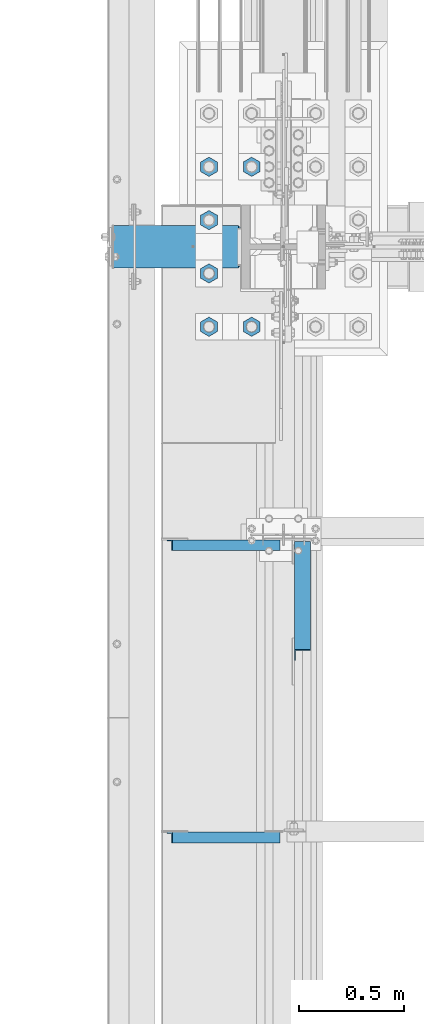
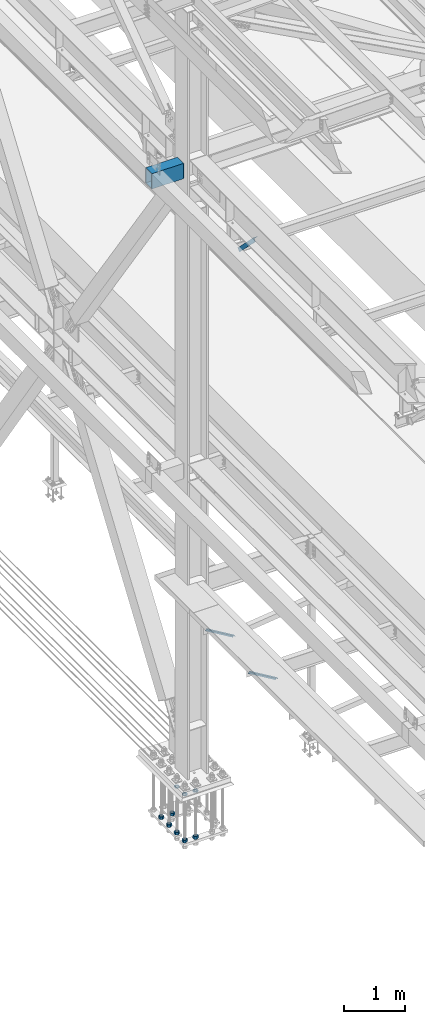
# One storey, part 2364 of 3843: 10 beams, 3 members, 5 elements without a shape of their own.
"""IFC2X3 building model written with IfcOpenShell, lengths in millimetres."""

from ifc_helpers import new_model, si_unit, frame, origin_with_axes, place, context, subcontext, project, spatial, faceted_brep, material, type_object, element, aggregate, save


model = new_model("IFC2X3")

# Units and contexts
model_context = context("Model", 3, precision=1e-05, world=origin_with_axes())
body_context = subcontext(model_context, "Body", "Model", "MODEL_VIEW")
ifc_project = project(units=[si_unit("LENGTHUNIT", "METRE", prefix="MILLI"), si_unit("AREAUNIT", "SQUARE_METRE"), si_unit("VOLUMEUNIT", "CUBIC_METRE"), si_unit("MASSUNIT", "GRAM", prefix="KILO"), si_unit("TIMEUNIT", "SECOND"), si_unit("PLANEANGLEUNIT", "RADIAN"), si_unit("SOLIDANGLEUNIT", "STERADIAN"), si_unit("THERMODYNAMICTEMPERATUREUNIT", "DEGREE_CELSIUS"), si_unit("LUMINOUSINTENSITYUNIT", "LUMEN")], contexts=[model_context])

# Site, building, storey
site_placement = place(None, origin_with_axes())
site = spatial("IfcSite", under=ifc_project, at=site_placement, CompositionType="ELEMENT")
building_placement = place(site_placement, origin_with_axes())
building = spatial("IfcBuilding", under=site, at=building_placement, Name="Undefined", CompositionType="ELEMENT")
storey_placement = place(building_placement, origin_with_axes())
storey = spatial("IfcBuildingStorey", under=building, at=storey_placement, Name="Undefined", CompositionType="ELEMENT", Elevation=0.0)

# Assembly, beams
assembly_1_placement = place(storey_placement, origin_with_axes())
assembly_1 = element("IfcElementAssembly", 1, at=assembly_1_placement, inside=storey, Name="TEMPLATE", AssemblyPlace="NOTDEFINED", PredefinedType="RIGID_FRAME")
ifc_material_1 = material(Name="STEEL/A572-50")
beam_type_1 = type_object("IfcBeamType", Name="2_HALF_NUT", PredefinedType="NOTDEFINED")
beam_1_placement = place(assembly_1_placement, frame((36423.6, 66890.9, 30060.9), z_axis=(-1.0, 0.0, 0.0), x_axis=(0.0, 0.0, -1.0)))
beam_1 = element("IfcBeam", 2, at=beam_1_placement, type_object=beam_type_1, material=ifc_material_1, Name="NUT", ObjectType="2_HALF_NUT", context=body_context, shape_type="Brep", body=[
    faceted_brep([(0.0, -46.0369987487793, 0.0), (0.0, -23.0184993743896, -39.869213104248), (25.4000000000015, -23.0184993743896, -39.869213104248), (25.4000000000015, -46.0369987487793, 0.0), (0.0, 23.0184993743896, -39.869213104248), (25.4000000000015, 23.0184993743896, -39.869213104248), (0.0, 46.0369987487793, 0.0), (25.4000000000015, 46.0369987487793, 0.0), (0.0, 23.0184993743896, 39.869213104248), (25.4000000000015, 23.0184993743896, 39.869213104248), (0.0, -23.0184993743896, 39.869213104248), (25.4000000000015, -23.0184993743896, 39.869213104248), (0.0, 0.0, 26.1940002441406), (0.0, 11.3650617044477, 23.5999013092805), (25.4000000000015, 11.3650617044477, 23.5999013092805), (25.4000000000015, 0.0, 26.1940002441406), (0.0, 20.4791109456419, 16.3316083006721), (25.4000000000015, 20.4791109456419, 16.3316083006721), (0.0, 25.5370200498292, 5.82867859874386), (25.4000000000015, 25.5370200498292, 5.82867859874386), (0.0, 25.5370200498292, -5.82867859874386), (25.4000000000015, 25.5370200498292, -5.82867859874386), (0.0, 20.4791109456419, -16.3316083006721), (25.4000000000015, 20.4791109456419, -16.3316083006721), (0.0, 11.3650617044477, -23.5999013092805), (25.4000000000015, 11.3650617044477, -23.5999013092805), (0.0, 0.0, -26.1940002441406), (25.4000000000015, 0.0, -26.1940002441406), (0.0, -11.3650617044477, -23.5999013092805), (25.4000000000015, -11.3650617044477, -23.5999013092805), (0.0, -20.4791109456419, -16.3316083006721), (25.4000000000015, -20.4791109456419, -16.3316083006721), (0.0, -25.5370200498292, -5.82867859874386), (25.4000000000015, -25.5370200498292, -5.82867859874386), (0.0, -25.5370200498292, 5.82867859874386), (25.4000000000015, -25.5370200498292, 5.82867859874386), (0.0, -20.4791109456419, 16.3316083006721), (25.4000000000015, -20.4791109456419, 16.3316083006721), (0.0, -11.3650617044477, 23.5999013092805), (25.4000000000015, -11.3650617044477, 23.5999013092805)], [[[0, 1, 2, 3]], [[1, 4, 5, 2]], [[4, 6, 7, 5]], [[6, 8, 9, 7]], [[8, 10, 11, 9]], [[10, 0, 3, 11]], [[12, 13, 14, 15]], [[13, 16, 17, 14]], [[16, 18, 19, 17]], [[18, 20, 21, 19]], [[20, 22, 23, 21]], [[22, 24, 25, 23]], [[24, 26, 27, 25]], [[26, 28, 29, 27]], [[28, 30, 31, 29]], [[30, 32, 33, 31]], [[32, 34, 35, 33]], [[34, 36, 37, 35]], [[36, 38, 39, 37]], [[38, 12, 15, 39]], [[5, 7, 9, 11, 3, 2], [17, 19, 21, 23, 25, 27, 29, 31, 33, 35, 37, 39, 15, 14]], [[10, 8, 6, 4, 1, 0], [38, 36, 34, 32, 30, 28, 26, 24, 22, 20, 18, 16, 13, 12]]]),
])
beam_2_placement = place(assembly_1_placement, frame((36220.4, 66890.9, 30060.9), z_axis=(-1.0, 0.0, 0.0), x_axis=(0.0, 0.0, -1.0)))
beam_2 = element("IfcBeam", 3, at=beam_2_placement, type_object=beam_type_1, material=ifc_material_1, Name="NUT", ObjectType="2_HALF_NUT", context=body_context, shape_type="Brep", body=[
    faceted_brep([(0.0, -46.0369987487793, 0.0), (0.0, -23.0184993743896, -39.869213104248), (25.4000000000015, -23.0184993743896, -39.869213104248), (25.4000000000015, -46.0369987487793, 0.0), (0.0, 23.0184993743896, -39.869213104248), (25.4000000000015, 23.0184993743896, -39.869213104248), (0.0, 46.0369987487793, 0.0), (25.4000000000015, 46.0369987487793, 0.0), (0.0, 23.0184993743896, 39.869213104248), (25.4000000000015, 23.0184993743896, 39.869213104248), (0.0, -23.0184993743896, 39.869213104248), (25.4000000000015, -23.0184993743896, 39.869213104248), (0.0, 0.0, 26.1940002441406), (0.0, 11.3650617044477, 23.5999013092805), (25.4000000000015, 11.3650617044477, 23.5999013092805), (25.4000000000015, 0.0, 26.1940002441406), (0.0, 20.4791109456419, 16.3316083006721), (25.4000000000015, 20.4791109456419, 16.3316083006721), (0.0, 25.5370200498292, 5.82867859874386), (25.4000000000015, 25.5370200498292, 5.82867859874386), (0.0, 25.5370200498292, -5.82867859874386), (25.4000000000015, 25.5370200498292, -5.82867859874386), (0.0, 20.4791109456419, -16.3316083006721), (25.4000000000015, 20.4791109456419, -16.3316083006721), (0.0, 11.3650617044477, -23.5999013092805), (25.4000000000015, 11.3650617044477, -23.5999013092805), (0.0, 0.0, -26.1940002441406), (25.4000000000015, 0.0, -26.1940002441406), (0.0, -11.3650617044477, -23.5999013092805), (25.4000000000015, -11.3650617044477, -23.5999013092805), (0.0, -20.4791109456419, -16.3316083006721), (25.4000000000015, -20.4791109456419, -16.3316083006721), (0.0, -25.5370200498292, -5.82867859874386), (25.4000000000015, -25.5370200498292, -5.82867859874386), (0.0, -25.5370200498292, 5.82867859874386), (25.4000000000015, -25.5370200498292, 5.82867859874386), (0.0, -20.4791109456419, 16.3316083006721), (25.4000000000015, -20.4791109456419, 16.3316083006721), (0.0, -11.3650617044477, 23.5999013092805), (25.4000000000015, -11.3650617044477, 23.5999013092805)], [[[0, 1, 2, 3]], [[1, 4, 5, 2]], [[4, 6, 7, 5]], [[6, 8, 9, 7]], [[8, 10, 11, 9]], [[10, 0, 3, 11]], [[12, 13, 14, 15]], [[13, 16, 17, 14]], [[16, 18, 19, 17]], [[18, 20, 21, 19]], [[20, 22, 23, 21]], [[22, 24, 25, 23]], [[24, 26, 27, 25]], [[26, 28, 29, 27]], [[28, 30, 31, 29]], [[30, 32, 33, 31]], [[32, 34, 35, 33]], [[34, 36, 37, 35]], [[36, 38, 39, 37]], [[38, 12, 15, 39]], [[5, 7, 9, 11, 3, 2], [17, 19, 21, 23, 25, 27, 29, 31, 33, 35, 37, 39, 15, 14]], [[10, 8, 6, 4, 1, 0], [38, 36, 34, 32, 30, 28, 26, 24, 22, 20, 18, 16, 13, 12]]]),
])
beam_3_placement = place(assembly_1_placement, frame((36220.4, 67144.9, 30060.9), z_axis=(-1.0, 0.0, 0.0), x_axis=(0.0, 0.0, -1.0)))
beam_3 = element("IfcBeam", 4, at=beam_3_placement, type_object=beam_type_1, material=ifc_material_1, Name="NUT", ObjectType="2_HALF_NUT", context=body_context, shape_type="Brep", body=[
    faceted_brep([(0.0, -46.0369987487793, 0.0), (0.0, -23.0184993743896, -39.869213104248), (25.4000000000015, -23.0184993743896, -39.869213104248), (25.4000000000015, -46.0369987487793, 0.0), (0.0, 23.0184993743896, -39.869213104248), (25.4000000000015, 23.0184993743896, -39.869213104248), (0.0, 46.0369987487793, 0.0), (25.4000000000015, 46.0369987487793, 0.0), (0.0, 23.0184993743896, 39.869213104248), (25.4000000000015, 23.0184993743896, 39.869213104248), (0.0, -23.0184993743896, 39.869213104248), (25.4000000000015, -23.0184993743896, 39.869213104248), (0.0, 0.0, 26.1940002441406), (0.0, 11.3650617044477, 23.5999013092805), (25.4000000000015, 11.3650617044477, 23.5999013092805), (25.4000000000015, 0.0, 26.1940002441406), (0.0, 20.4791109456419, 16.3316083006721), (25.4000000000015, 20.4791109456419, 16.3316083006721), (0.0, 25.5370200498292, 5.82867859874386), (25.4000000000015, 25.5370200498292, 5.82867859874386), (0.0, 25.5370200498292, -5.82867859874386), (25.4000000000015, 25.5370200498292, -5.82867859874386), (0.0, 20.4791109456419, -16.3316083006721), (25.4000000000015, 20.4791109456419, -16.3316083006721), (0.0, 11.3650617044477, -23.5999013092805), (25.4000000000015, 11.3650617044477, -23.5999013092805), (0.0, 0.0, -26.1940002441406), (25.4000000000015, 0.0, -26.1940002441406), (0.0, -11.3650617044477, -23.5999013092805), (25.4000000000015, -11.3650617044477, -23.5999013092805), (0.0, -20.4791109456419, -16.3316083006721), (25.4000000000015, -20.4791109456419, -16.3316083006721), (0.0, -25.5370200498292, -5.82867859874386), (25.4000000000015, -25.5370200498292, -5.82867859874386), (0.0, -25.5370200498292, 5.82867859874386), (25.4000000000015, -25.5370200498292, 5.82867859874386), (0.0, -20.4791109456419, 16.3316083006721), (25.4000000000015, -20.4791109456419, 16.3316083006721), (0.0, -11.3650617044477, 23.5999013092805), (25.4000000000015, -11.3650617044477, 23.5999013092805)], [[[0, 1, 2, 3]], [[1, 4, 5, 2]], [[4, 6, 7, 5]], [[6, 8, 9, 7]], [[8, 10, 11, 9]], [[10, 0, 3, 11]], [[12, 13, 14, 15]], [[13, 16, 17, 14]], [[16, 18, 19, 17]], [[18, 20, 21, 19]], [[20, 22, 23, 21]], [[22, 24, 25, 23]], [[24, 26, 27, 25]], [[26, 28, 29, 27]], [[28, 30, 31, 29]], [[30, 32, 33, 31]], [[32, 34, 35, 33]], [[34, 36, 37, 35]], [[36, 38, 39, 37]], [[38, 12, 15, 39]], [[5, 7, 9, 11, 3, 2], [17, 19, 21, 23, 25, 27, 29, 31, 33, 35, 37, 39, 15, 14]], [[10, 8, 6, 4, 1, 0], [38, 36, 34, 32, 30, 28, 26, 24, 22, 20, 18, 16, 13, 12]]]),
])
beam_type_2 = type_object("IfcBeamType", Name="2_HEAVY_HEX_NUT", PredefinedType="NOTDEFINED")
beam_4_placement = place(assembly_1_placement, frame((36423.6, 66890.9, 29159.2), z_axis=(1.0, 0.0, 0.0), x_axis=(0.0, 0.0, -1.0)))
beam_4 = element("IfcBeam", 5, at=beam_4_placement, type_object=beam_type_2, material=ifc_material_1, Name="NUT", ObjectType="2_HEAVY_HEX_NUT", context=body_context, shape_type="Brep", body=[
    faceted_brep([(0.0, -46.0369987487793, 0.0), (0.0, -23.0184993743896, -39.869213104248), (50.7999999999993, -23.0184993743896, -39.869213104248), (50.7999999999993, -46.0369987487793, 0.0), (0.0, 23.0184993743896, -39.869213104248), (50.7999999999993, 23.0184993743896, -39.869213104248), (0.0, 46.0369987487793, 0.0), (50.7999999999993, 46.0369987487793, 0.0), (0.0, 23.0184993743896, 39.869213104248), (50.7999999999993, 23.0184993743896, 39.869213104248), (0.0, -23.0184993743896, 39.869213104248), (50.7999999999993, -23.0184993743896, 39.869213104248), (0.0, 0.0, 26.1940002441406), (0.0, 11.3650617044477, 23.5999013092805), (50.7999999999993, 11.3650617044477, 23.5999013092805), (50.7999999999993, 0.0, 26.1940002441406), (0.0, 20.4791109456419, 16.3316083006721), (50.7999999999993, 20.4791109456419, 16.3316083006721), (0.0, 25.5370200498292, 5.82867859874386), (50.7999999999993, 25.5370200498292, 5.82867859874386), (0.0, 25.5370200498292, -5.82867859874386), (50.7999999999993, 25.5370200498292, -5.82867859874386), (0.0, 20.4791109456419, -16.3316083006721), (50.7999999999993, 20.4791109456419, -16.3316083006721), (0.0, 11.3650617044477, -23.5999013092805), (50.7999999999993, 11.3650617044477, -23.5999013092805), (0.0, 0.0, -26.1940002441406), (50.7999999999993, 0.0, -26.1940002441406), (0.0, -11.3650617044477, -23.5999013092805), (50.7999999999993, -11.3650617044477, -23.5999013092805), (0.0, -20.4791109456419, -16.3316083006721), (50.7999999999993, -20.4791109456419, -16.3316083006721), (0.0, -25.5370200498292, -5.82867859874386), (50.7999999999993, -25.5370200498292, -5.82867859874386), (0.0, -25.5370200498292, 5.82867859874386), (50.7999999999993, -25.5370200498292, 5.82867859874386), (0.0, -20.4791109456419, 16.3316083006721), (50.7999999999993, -20.4791109456419, 16.3316083006721), (0.0, -11.3650617044477, 23.5999013092805), (50.7999999999993, -11.3650617044477, 23.5999013092805)], [[[0, 1, 2, 3]], [[1, 4, 5, 2]], [[4, 6, 7, 5]], [[6, 8, 9, 7]], [[8, 10, 11, 9]], [[10, 0, 3, 11]], [[12, 13, 14, 15]], [[13, 16, 17, 14]], [[16, 18, 19, 17]], [[18, 20, 21, 19]], [[20, 22, 23, 21]], [[22, 24, 25, 23]], [[24, 26, 27, 25]], [[26, 28, 29, 27]], [[28, 30, 31, 29]], [[30, 32, 33, 31]], [[32, 34, 35, 33]], [[34, 36, 37, 35]], [[36, 38, 39, 37]], [[38, 12, 15, 39]], [[5, 7, 9, 11, 3, 2], [17, 19, 21, 23, 25, 27, 29, 31, 33, 35, 37, 39, 15, 14]], [[10, 8, 6, 4, 1, 0], [38, 36, 34, 32, 30, 28, 26, 24, 22, 20, 18, 16, 13, 12]]]),
])
beam_5_placement = place(assembly_1_placement, frame((36220.4, 66890.9, 29159.2), z_axis=(1.0, 0.0, 0.0), x_axis=(0.0, 0.0, -1.0)))
beam_5 = element("IfcBeam", 6, at=beam_5_placement, type_object=beam_type_2, material=ifc_material_1, Name="NUT", ObjectType="2_HEAVY_HEX_NUT", context=body_context, shape_type="Brep", body=[
    faceted_brep([(0.0, -46.0369987487793, 0.0), (0.0, -23.0184993743896, -39.869213104248), (50.7999999999993, -23.0184993743896, -39.869213104248), (50.7999999999993, -46.0369987487793, 0.0), (0.0, 23.0184993743896, -39.869213104248), (50.7999999999993, 23.0184993743896, -39.869213104248), (0.0, 46.0369987487793, 0.0), (50.7999999999993, 46.0369987487793, 0.0), (0.0, 23.0184993743896, 39.869213104248), (50.7999999999993, 23.0184993743896, 39.869213104248), (0.0, -23.0184993743896, 39.869213104248), (50.7999999999993, -23.0184993743896, 39.869213104248), (0.0, 0.0, 26.1940002441406), (0.0, 11.3650617044477, 23.5999013092805), (50.7999999999993, 11.3650617044477, 23.5999013092805), (50.7999999999993, 0.0, 26.1940002441406), (0.0, 20.4791109456419, 16.3316083006721), (50.7999999999993, 20.4791109456419, 16.3316083006721), (0.0, 25.5370200498292, 5.82867859874386), (50.7999999999993, 25.5370200498292, 5.82867859874386), (0.0, 25.5370200498292, -5.82867859874386), (50.7999999999993, 25.5370200498292, -5.82867859874386), (0.0, 20.4791109456419, -16.3316083006721), (50.7999999999993, 20.4791109456419, -16.3316083006721), (0.0, 11.3650617044477, -23.5999013092805), (50.7999999999993, 11.3650617044477, -23.5999013092805), (0.0, 0.0, -26.1940002441406), (50.7999999999993, 0.0, -26.1940002441406), (0.0, -11.3650617044477, -23.5999013092805), (50.7999999999993, -11.3650617044477, -23.5999013092805), (0.0, -20.4791109456419, -16.3316083006721), (50.7999999999993, -20.4791109456419, -16.3316083006721), (0.0, -25.5370200498292, -5.82867859874386), (50.7999999999993, -25.5370200498292, -5.82867859874386), (0.0, -25.5370200498292, 5.82867859874386), (50.7999999999993, -25.5370200498292, 5.82867859874386), (0.0, -20.4791109456419, 16.3316083006721), (50.7999999999993, -20.4791109456419, 16.3316083006721), (0.0, -11.3650617044477, 23.5999013092805), (50.7999999999993, -11.3650617044477, 23.5999013092805)], [[[0, 1, 2, 3]], [[1, 4, 5, 2]], [[4, 6, 7, 5]], [[6, 8, 9, 7]], [[8, 10, 11, 9]], [[10, 0, 3, 11]], [[12, 13, 14, 15]], [[13, 16, 17, 14]], [[16, 18, 19, 17]], [[18, 20, 21, 19]], [[20, 22, 23, 21]], [[22, 24, 25, 23]], [[24, 26, 27, 25]], [[26, 28, 29, 27]], [[28, 30, 31, 29]], [[30, 32, 33, 31]], [[32, 34, 35, 33]], [[34, 36, 37, 35]], [[36, 38, 39, 37]], [[38, 12, 15, 39]], [[5, 7, 9, 11, 3, 2], [17, 19, 21, 23, 25, 27, 29, 31, 33, 35, 37, 39, 15, 14]], [[10, 8, 6, 4, 1, 0], [38, 36, 34, 32, 30, 28, 26, 24, 22, 20, 18, 16, 13, 12]]]),
])
beam_6_placement = place(assembly_1_placement, frame((36423.6, 67652.9, 29159.2), z_axis=(-1.0, 0.0, 0.0), x_axis=(0.0, 0.0, -1.0)))
beam_6 = element("IfcBeam", 7, at=beam_6_placement, type_object=beam_type_2, material=ifc_material_1, Name="NUT", ObjectType="2_HEAVY_HEX_NUT", context=body_context, shape_type="Brep", body=[
    faceted_brep([(0.0, -46.0369987487793, 0.0), (0.0, -23.0184993743896, -39.869213104248), (50.7999999999993, -23.0184993743896, -39.869213104248), (50.7999999999993, -46.0369987487793, 0.0), (0.0, 23.0184993743896, -39.869213104248), (50.7999999999993, 23.0184993743896, -39.869213104248), (0.0, 46.0369987487793, 0.0), (50.7999999999993, 46.0369987487793, 0.0), (0.0, 23.0184993743896, 39.869213104248), (50.7999999999993, 23.0184993743896, 39.869213104248), (0.0, -23.0184993743896, 39.869213104248), (50.7999999999993, -23.0184993743896, 39.869213104248), (0.0, 0.0, 26.1940002441406), (0.0, 11.3650617044477, 23.5999013092805), (50.7999999999993, 11.3650617044477, 23.5999013092805), (50.7999999999993, 0.0, 26.1940002441406), (0.0, 20.4791109456419, 16.3316083006721), (50.7999999999993, 20.4791109456419, 16.3316083006721), (0.0, 25.5370200498292, 5.82867859874386), (50.7999999999993, 25.5370200498292, 5.82867859874386), (0.0, 25.5370200498292, -5.82867859874386), (50.7999999999993, 25.5370200498292, -5.82867859874386), (0.0, 20.4791109456419, -16.3316083006721), (50.7999999999993, 20.4791109456419, -16.3316083006721), (0.0, 11.3650617044477, -23.5999013092805), (50.7999999999993, 11.3650617044477, -23.5999013092805), (0.0, 0.0, -26.1940002441406), (50.7999999999993, 0.0, -26.1940002441406), (0.0, -11.3650617044477, -23.5999013092805), (50.7999999999993, -11.3650617044477, -23.5999013092805), (0.0, -20.4791109456419, -16.3316083006721), (50.7999999999993, -20.4791109456419, -16.3316083006721), (0.0, -25.5370200498292, -5.82867859874386), (50.7999999999993, -25.5370200498292, -5.82867859874386), (0.0, -25.5370200498292, 5.82867859874386), (50.7999999999993, -25.5370200498292, 5.82867859874386), (0.0, -20.4791109456419, 16.3316083006721), (50.7999999999993, -20.4791109456419, 16.3316083006721), (0.0, -11.3650617044477, 23.5999013092805), (50.7999999999993, -11.3650617044477, 23.5999013092805)], [[[0, 1, 2, 3]], [[1, 4, 5, 2]], [[4, 6, 7, 5]], [[6, 8, 9, 7]], [[8, 10, 11, 9]], [[10, 0, 3, 11]], [[12, 13, 14, 15]], [[13, 16, 17, 14]], [[16, 18, 19, 17]], [[18, 20, 21, 19]], [[20, 22, 23, 21]], [[22, 24, 25, 23]], [[24, 26, 27, 25]], [[26, 28, 29, 27]], [[28, 30, 31, 29]], [[30, 32, 33, 31]], [[32, 34, 35, 33]], [[34, 36, 37, 35]], [[36, 38, 39, 37]], [[38, 12, 15, 39]], [[5, 7, 9, 11, 3, 2], [17, 19, 21, 23, 25, 27, 29, 31, 33, 35, 37, 39, 15, 14]], [[10, 8, 6, 4, 1, 0], [38, 36, 34, 32, 30, 28, 26, 24, 22, 20, 18, 16, 13, 12]]]),
])
beam_7_placement = place(assembly_1_placement, frame((36220.4, 67144.9, 29159.2), z_axis=(1.0, 0.0, 0.0), x_axis=(0.0, 0.0, -1.0)))
beam_7 = element("IfcBeam", 8, at=beam_7_placement, type_object=beam_type_2, material=ifc_material_1, Name="NUT", ObjectType="2_HEAVY_HEX_NUT", context=body_context, shape_type="Brep", body=[
    faceted_brep([(0.0, -46.0369987487793, 0.0), (0.0, -23.0184993743896, -39.869213104248), (50.7999999999993, -23.0184993743896, -39.869213104248), (50.7999999999993, -46.0369987487793, 0.0), (0.0, 23.0184993743896, -39.869213104248), (50.7999999999993, 23.0184993743896, -39.869213104248), (0.0, 46.0369987487793, 0.0), (50.7999999999993, 46.0369987487793, 0.0), (0.0, 23.0184993743896, 39.869213104248), (50.7999999999993, 23.0184993743896, 39.869213104248), (0.0, -23.0184993743896, 39.869213104248), (50.7999999999993, -23.0184993743896, 39.869213104248), (0.0, 0.0, 26.1940002441406), (0.0, 11.3650617044477, 23.5999013092805), (50.7999999999993, 11.3650617044477, 23.5999013092805), (50.7999999999993, 0.0, 26.1940002441406), (0.0, 20.4791109456419, 16.3316083006721), (50.7999999999993, 20.4791109456419, 16.3316083006721), (0.0, 25.5370200498292, 5.82867859874386), (50.7999999999993, 25.5370200498292, 5.82867859874386), (0.0, 25.5370200498292, -5.82867859874386), (50.7999999999993, 25.5370200498292, -5.82867859874386), (0.0, 20.4791109456419, -16.3316083006721), (50.7999999999993, 20.4791109456419, -16.3316083006721), (0.0, 11.3650617044477, -23.5999013092805), (50.7999999999993, 11.3650617044477, -23.5999013092805), (0.0, 0.0, -26.1940002441406), (50.7999999999993, 0.0, -26.1940002441406), (0.0, -11.3650617044477, -23.5999013092805), (50.7999999999993, -11.3650617044477, -23.5999013092805), (0.0, -20.4791109456419, -16.3316083006721), (50.7999999999993, -20.4791109456419, -16.3316083006721), (0.0, -25.5370200498292, -5.82867859874386), (50.7999999999993, -25.5370200498292, -5.82867859874386), (0.0, -25.5370200498292, 5.82867859874386), (50.7999999999993, -25.5370200498292, 5.82867859874386), (0.0, -20.4791109456419, 16.3316083006721), (50.7999999999993, -20.4791109456419, 16.3316083006721), (0.0, -11.3650617044477, 23.5999013092805), (50.7999999999993, -11.3650617044477, 23.5999013092805)], [[[0, 1, 2, 3]], [[1, 4, 5, 2]], [[4, 6, 7, 5]], [[6, 8, 9, 7]], [[8, 10, 11, 9]], [[10, 0, 3, 11]], [[12, 13, 14, 15]], [[13, 16, 17, 14]], [[16, 18, 19, 17]], [[18, 20, 21, 19]], [[20, 22, 23, 21]], [[22, 24, 25, 23]], [[24, 26, 27, 25]], [[26, 28, 29, 27]], [[28, 30, 31, 29]], [[30, 32, 33, 31]], [[32, 34, 35, 33]], [[34, 36, 37, 35]], [[36, 38, 39, 37]], [[38, 12, 15, 39]], [[5, 7, 9, 11, 3, 2], [17, 19, 21, 23, 25, 27, 29, 31, 33, 35, 37, 39, 15, 14]], [[10, 8, 6, 4, 1, 0], [38, 36, 34, 32, 30, 28, 26, 24, 22, 20, 18, 16, 13, 12]]]),
])
beam_8_placement = place(assembly_1_placement, frame((36220.4, 67398.9, 29159.2), z_axis=(1.0, 0.0, 0.0), x_axis=(0.0, 0.0, -1.0)))
beam_8 = element("IfcBeam", 9, at=beam_8_placement, type_object=beam_type_2, material=ifc_material_1, Name="NUT", ObjectType="2_HEAVY_HEX_NUT", context=body_context, shape_type="Brep", body=[
    faceted_brep([(0.0, -46.0369987487793, 0.0), (0.0, -23.0184993743896, -39.869213104248), (50.7999999999993, -23.0184993743896, -39.869213104248), (50.7999999999993, -46.0369987487793, 0.0), (0.0, 23.0184993743896, -39.869213104248), (50.7999999999993, 23.0184993743896, -39.869213104248), (0.0, 46.0369987487793, 0.0), (50.7999999999993, 46.0369987487793, 0.0), (0.0, 23.0184993743896, 39.869213104248), (50.7999999999993, 23.0184993743896, 39.869213104248), (0.0, -23.0184993743896, 39.869213104248), (50.7999999999993, -23.0184993743896, 39.869213104248), (0.0, 0.0, 26.1940002441406), (0.0, 11.3650617044477, 23.5999013092805), (50.7999999999993, 11.3650617044477, 23.5999013092805), (50.7999999999993, 0.0, 26.1940002441406), (0.0, 20.4791109456419, 16.3316083006721), (50.7999999999993, 20.4791109456419, 16.3316083006721), (0.0, 25.5370200498292, 5.82867859874386), (50.7999999999993, 25.5370200498292, 5.82867859874386), (0.0, 25.5370200498292, -5.82867859874386), (50.7999999999993, 25.5370200498292, -5.82867859874386), (0.0, 20.4791109456419, -16.3316083006721), (50.7999999999993, 20.4791109456419, -16.3316083006721), (0.0, 11.3650617044477, -23.5999013092805), (50.7999999999993, 11.3650617044477, -23.5999013092805), (0.0, 0.0, -26.1940002441406), (50.7999999999993, 0.0, -26.1940002441406), (0.0, -11.3650617044477, -23.5999013092805), (50.7999999999993, -11.3650617044477, -23.5999013092805), (0.0, -20.4791109456419, -16.3316083006721), (50.7999999999993, -20.4791109456419, -16.3316083006721), (0.0, -25.5370200498292, -5.82867859874386), (50.7999999999993, -25.5370200498292, -5.82867859874386), (0.0, -25.5370200498292, 5.82867859874386), (50.7999999999993, -25.5370200498292, 5.82867859874386), (0.0, -20.4791109456419, 16.3316083006721), (50.7999999999993, -20.4791109456419, 16.3316083006721), (0.0, -11.3650617044477, 23.5999013092805), (50.7999999999993, -11.3650617044477, 23.5999013092805)], [[[0, 1, 2, 3]], [[1, 4, 5, 2]], [[4, 6, 7, 5]], [[6, 8, 9, 7]], [[8, 10, 11, 9]], [[10, 0, 3, 11]], [[12, 13, 14, 15]], [[13, 16, 17, 14]], [[16, 18, 19, 17]], [[18, 20, 21, 19]], [[20, 22, 23, 21]], [[22, 24, 25, 23]], [[24, 26, 27, 25]], [[26, 28, 29, 27]], [[28, 30, 31, 29]], [[30, 32, 33, 31]], [[32, 34, 35, 33]], [[34, 36, 37, 35]], [[36, 38, 39, 37]], [[38, 12, 15, 39]], [[5, 7, 9, 11, 3, 2], [17, 19, 21, 23, 25, 27, 29, 31, 33, 35, 37, 39, 15, 14]], [[10, 8, 6, 4, 1, 0], [38, 36, 34, 32, 30, 28, 26, 24, 22, 20, 18, 16, 13, 12]]]),
])
beam_9_placement = place(assembly_1_placement, frame((36220.4, 67652.9, 29159.2), z_axis=(-1.0, 0.0, 0.0), x_axis=(0.0, 0.0, -1.0)))
beam_9 = element("IfcBeam", 10, at=beam_9_placement, type_object=beam_type_2, material=ifc_material_1, Name="NUT", ObjectType="2_HEAVY_HEX_NUT", context=body_context, shape_type="Brep", body=[
    faceted_brep([(0.0, -46.0369987487793, 0.0), (0.0, -23.0184993743896, -39.869213104248), (50.7999999999993, -23.0184993743896, -39.869213104248), (50.7999999999993, -46.0369987487793, 0.0), (0.0, 23.0184993743896, -39.869213104248), (50.7999999999993, 23.0184993743896, -39.869213104248), (0.0, 46.0369987487793, 0.0), (50.7999999999993, 46.0369987487793, 0.0), (0.0, 23.0184993743896, 39.869213104248), (50.7999999999993, 23.0184993743896, 39.869213104248), (0.0, -23.0184993743896, 39.869213104248), (50.7999999999993, -23.0184993743896, 39.869213104248), (0.0, 0.0, 26.1940002441406), (0.0, 11.3650617044477, 23.5999013092805), (50.7999999999993, 11.3650617044477, 23.5999013092805), (50.7999999999993, 0.0, 26.1940002441406), (0.0, 20.4791109456419, 16.3316083006721), (50.7999999999993, 20.4791109456419, 16.3316083006721), (0.0, 25.5370200498292, 5.82867859874386), (50.7999999999993, 25.5370200498292, 5.82867859874386), (0.0, 25.5370200498292, -5.82867859874386), (50.7999999999993, 25.5370200498292, -5.82867859874386), (0.0, 20.4791109456419, -16.3316083006721), (50.7999999999993, 20.4791109456419, -16.3316083006721), (0.0, 11.3650617044477, -23.5999013092805), (50.7999999999993, 11.3650617044477, -23.5999013092805), (0.0, 0.0, -26.1940002441406), (50.7999999999993, 0.0, -26.1940002441406), (0.0, -11.3650617044477, -23.5999013092805), (50.7999999999993, -11.3650617044477, -23.5999013092805), (0.0, -20.4791109456419, -16.3316083006721), (50.7999999999993, -20.4791109456419, -16.3316083006721), (0.0, -25.5370200498292, -5.82867859874386), (50.7999999999993, -25.5370200498292, -5.82867859874386), (0.0, -25.5370200498292, 5.82867859874386), (50.7999999999993, -25.5370200498292, 5.82867859874386), (0.0, -20.4791109456419, 16.3316083006721), (50.7999999999993, -20.4791109456419, 16.3316083006721), (0.0, -11.3650617044477, 23.5999013092805), (50.7999999999993, -11.3650617044477, 23.5999013092805)], [[[0, 1, 2, 3]], [[1, 4, 5, 2]], [[4, 6, 7, 5]], [[6, 8, 9, 7]], [[8, 10, 11, 9]], [[10, 0, 3, 11]], [[12, 13, 14, 15]], [[13, 16, 17, 14]], [[16, 18, 19, 17]], [[18, 20, 21, 19]], [[20, 22, 23, 21]], [[22, 24, 25, 23]], [[24, 26, 27, 25]], [[26, 28, 29, 27]], [[28, 30, 31, 29]], [[30, 32, 33, 31]], [[32, 34, 35, 33]], [[34, 36, 37, 35]], [[36, 38, 39, 37]], [[38, 12, 15, 39]], [[5, 7, 9, 11, 3, 2], [17, 19, 21, 23, 25, 27, 29, 31, 33, 35, 37, 39, 15, 14]], [[10, 8, 6, 4, 1, 0], [38, 36, 34, 32, 30, 28, 26, 24, 22, 20, 18, 16, 13, 12]]]),
])
aggregate(assembly_1, [beam_4, beam_5, beam_6, beam_7, beam_8, beam_9, beam_1, beam_2, beam_3])

# Assembly, member
assembly_2_placement = place(storey_placement, origin_with_axes())
assembly_2 = element("IfcElementAssembly", 11, at=assembly_2_placement, inside=storey, Name="ANGLE", AssemblyPlace="NOTDEFINED", PredefinedType="RIGID_FRAME")
member_type_1 = type_object("IfcMemberType", Name="L2X2X1/4", PredefinedType="NOTDEFINED")
member_1_placement = place(assembly_2_placement, frame((36032.7062481198, 65850.492188, 34001.5027629153), z_axis=(0.0, -1.0, 0.0), x_axis=(0.858158898344811, 0.0, -0.513384169206278)))
member_1 = element("IfcMember", 12, at=member_1_placement, type_object=member_type_1, material=ifc_material_1, Name="ANGLE", ObjectType="L2X2X1/4", context=body_context, shape_type="Brep", body=[
    faceted_brep([(0.0, 25.4000000000015, -25.4000000000015), (0.0, 25.4000000000015, 25.4000000000015), (598.473132324763, 25.3999999988228, 25.3999999999942), (598.473132324763, 25.3999999988228, -25.3999999999942), (0.0, 19.0500000000029, 25.4000000000015), (598.473132324745, 19.0499999988242, 25.3999999999942), (0.0, 19.0500000000029, -19.0499999999993), (598.473132324745, 19.0499999988242, -19.0500000000029), (0.0, -25.4000000000015, -19.0499999999993), (598.473132324661, -25.4000000011511, -19.0500000000029), (0.0, -25.4000000000015, -25.4000000000015), (598.473132324661, -25.4000000011511, -25.3999999999942)], [[[0, 1, 2, 3]], [[1, 4, 5, 2]], [[4, 6, 7, 5]], [[6, 8, 9, 7]], [[8, 10, 11, 9]], [[10, 0, 3, 11]], [[5, 7, 9, 11, 3, 2]], [[10, 8, 6, 4, 1, 0]]]),
])
aggregate(assembly_2, [member_1])

assembly_3_placement = place(storey_placement, origin_with_axes())
assembly_3 = element("IfcElementAssembly", 13, at=assembly_3_placement, inside=storey, Name="ANGLE", AssemblyPlace="NOTDEFINED", PredefinedType="RIGID_FRAME")
member_2_placement = place(assembly_3_placement, frame((36032.7062481198, 64457.6593760001, 34001.5027629153), z_axis=(0.0, -1.0, 0.0), x_axis=(0.858158898344811, 0.0, -0.513384169206278)))
member_2 = element("IfcMember", 14, at=member_2_placement, type_object=member_type_1, material=ifc_material_1, Name="ANGLE", ObjectType="L2X2X1/4", context=body_context, shape_type="Brep", body=[
    faceted_brep([(0.0, 25.4000000000015, -25.4000000000015), (0.0, 25.4000000000015, 25.4000000000015), (598.473132324763, 25.3999999988228, 25.3999999999942), (598.473132324763, 25.3999999988228, -25.3999999999942), (0.0, 19.0500000000029, 25.4000000000015), (598.473132324745, 19.0499999988242, 25.3999999999942), (0.0, 19.0500000000029, -19.0499999999993), (598.473132324745, 19.0499999988242, -19.0500000000029), (0.0, -25.4000000000015, -19.0499999999993), (598.473132324661, -25.4000000011511, -19.0500000000029), (0.0, -25.4000000000015, -25.4000000000015), (598.473132324661, -25.4000000011511, -25.3999999999942)], [[[0, 1, 2, 3]], [[1, 4, 5, 2]], [[4, 6, 7, 5]], [[6, 8, 9, 7]], [[8, 10, 11, 9]], [[10, 0, 3, 11]], [[5, 7, 9, 11, 3, 2]], [[10, 8, 6, 4, 1, 0]]]),
])
aggregate(assembly_3, [member_2])

# Assembly, beam
assembly_4_placement = place(storey_placement, origin_with_axes())
assembly_4 = element("IfcElementAssembly", 15, at=assembly_4_placement, inside=storey, Name="COLUMN", AssemblyPlace="NOTDEFINED", PredefinedType="RIGID_FRAME")
ifc_material_2 = material()
beam_type_3 = type_object("IfcBeamType", Name="HSS12X8X3/8", PredefinedType="NOTDEFINED")
beam_10_placement = place(assembly_4_placement, frame((35760.025, 67271.9, 42214.8), z_axis=(0.0, 0.0, 1.0), x_axis=(1.0, 0.0, 0.0)))
beam_10 = element("IfcBeam", 16, at=beam_10_placement, type_object=beam_type_3, material=ifc_material_2, Name="GIRT", ObjectType="HSS12X8X3/8", context=body_context, shape_type="Brep", body=[
    faceted_brep([(609.600000000006, 92.0749999999971, 142.875), (609.600000000006, 92.0749999999971, -142.875), (600.075000000004, 101.600000000006, -152.400000000001), (600.075000000004, 101.600000000006, 152.400000000001), (609.600000000006, -92.0749999999971, -142.875), (600.075000000004, -101.600000000006, -152.400000000001), (609.600000000006, -92.0749999999971, 142.875), (600.075000000004, -101.600000000006, 152.400000000001), (6.35000000002037, 92.0749999999971, 142.875), (6.35000000002037, 92.0749999999971, -142.875), (6.35000000002037, -92.0749999999971, 142.875), (6.35000000002037, -92.0749999999971, -142.875), (6.35000000002037, -101.600000000006, -152.400000000001), (6.35000000002037, -101.600000000006, 152.400000000001), (6.35000000002037, 101.600000000006, 152.400000000001), (6.35000000002037, 101.600000000006, -152.400000000001)], [[[0, 1, 2, 3]], [[4, 5, 2, 1]], [[6, 7, 5, 4]], [[8, 9, 1, 0]], [[10, 8, 0, 6]], [[11, 10, 6, 4]], [[9, 11, 4, 1]], [[12, 13, 14, 15], [8, 10, 11, 9]], [[15, 14, 3, 2]], [[12, 15, 2, 5]], [[13, 12, 5, 7]], [[14, 13, 7, 3]], [[0, 3, 7, 6]]]),
])
aggregate(assembly_4, [beam_10])

# Assembly, member
assembly_5_placement = place(storey_placement, origin_with_axes())
assembly_5 = element("IfcElementAssembly", 17, at=assembly_5_placement, inside=storey, Name="ANGLE", AssemblyPlace="NOTDEFINED", PredefinedType="RIGID_FRAME")
member_type_2 = type_object("IfcMemberType", Name="L3X3X1/4", PredefinedType="NOTDEFINED")
member_3_placement = place(assembly_5_placement, frame((36664.9, 65900.3, 41300.4), z_axis=(0.0, -0.707106781186548, -0.707106781186548), x_axis=(0.0, -0.707106781186682, 0.707106781186413)))
member_3 = element("IfcMember", 18, at=member_3_placement, type_object=member_type_2, material=ifc_material_1, Name="ANGLE", ObjectType="L3X3X1/4", context=body_context, shape_type="Brep", body=[
    faceted_brep([(83.0012806675732, 38.0999999999985, -38.0999999999058), (83.0012806675732, -38.0999999999985, -38.0999999999058), (83.0012806675804, -38.0999999999985, -31.7499999999254), (83.0012806675804, 31.75, -31.7499999999254), (83.0012806675804, 31.75, 38.0999999999058), (83.0012806675804, 38.0999999999985, 38.0999999999058), (810.534203444928, 31.75, 38.0999999999112), (810.534203444928, 38.0999999999985, 38.0999999999112), (810.534203444538, 38.0999999999985, -38.099999999904), (810.534203444538, -38.0999999999985, -38.099999999904), (810.534203444575, -38.0999999999985, -31.7499999999272), (810.534203444575, 31.75, -31.7499999999272)], [[[0, 1, 2, 3, 4, 5]], [[5, 4, 6, 7]], [[0, 5, 7, 8]], [[1, 0, 8, 9]], [[2, 1, 9, 10]], [[3, 2, 10, 11]], [[4, 3, 11, 6]], [[10, 9, 8, 7, 6, 11]]]),
])
aggregate(assembly_5, [member_3])

save(model, "model.ifc")
